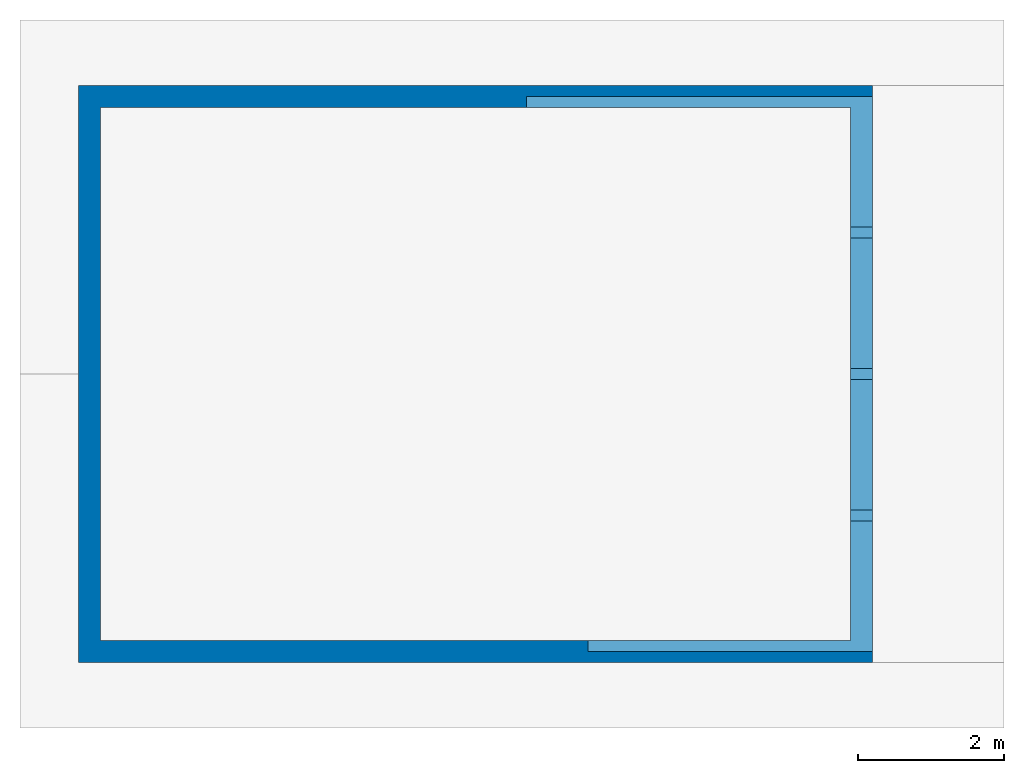
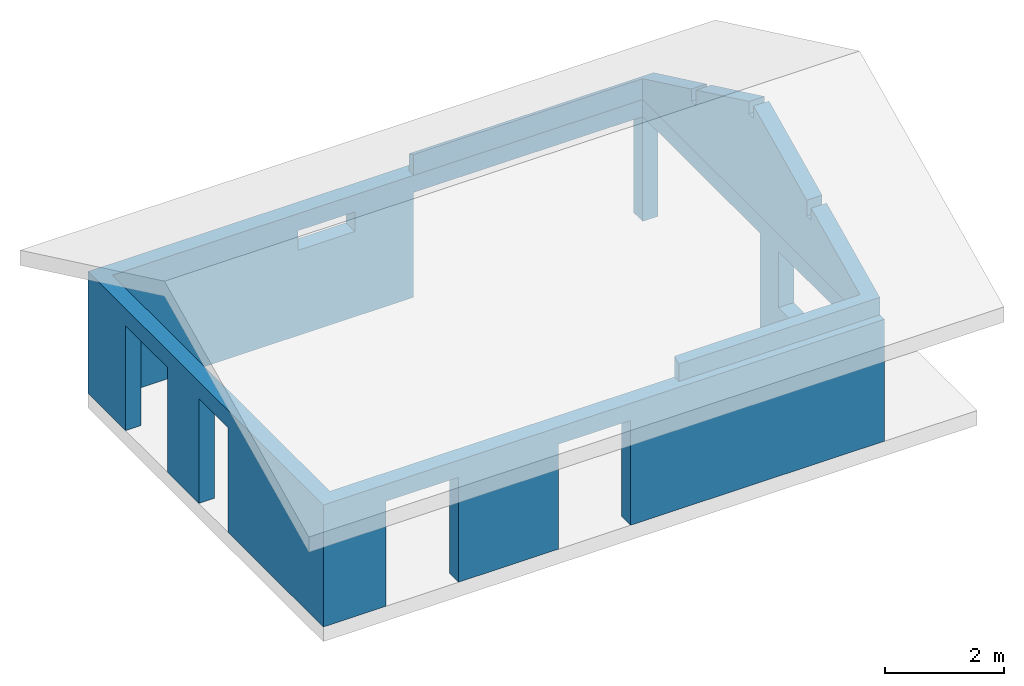
# Not in any storey, part 2 of 2: 2 walls.
"""IFC4 model written with IfcOpenShell, lengths in metres."""

from ifc_helpers import new_model, entity, si_unit, converted_unit, frame, frame_2d, origin_with_axes, place, context, subcontext, project, polygons, material, element, save


model = new_model("IFC4")

# Units and contexts
model_context = context("Model", 3, precision=1e-05, world=origin_with_axes())
plan_context = context("Plan", 2, precision=1e-05, world=frame_2d((0.0, 0.0, 0.0), x_axis=(1.0, 0.0, 0.0)))
body_context = subcontext(model_context, "Body", "Model", "MODEL_VIEW")
ifc_project = project(units=[converted_unit("PLANEANGLEUNIT", "degree", entity("IfcReal", 0.0174532925199433), si_unit("PLANEANGLEUNIT", "RADIAN"), dimensions=[0, 0, 0, 0, 0, 0, 0]), si_unit("AREAUNIT", "SQUARE_METRE"), si_unit("VOLUMEUNIT", "CUBIC_METRE"), si_unit("LENGTHUNIT", "METRE")], contexts=[model_context, plan_context])

# Walls
ifc_material = material(Name="brick")
wall_1_placement = place(None, frame((0.0, 0.0, 0.300000011920929), z_axis=(0.0, 0.0, 1.0), x_axis=(1.0, 0.0, 0.0)))
element("IfcWall", 1, at=wall_1_placement, material=ifc_material, PredefinedType="ELEMENTEDWALL", context=body_context, shape_type="Tessellation", body=[
    polygons([(-0.0500000007450581, 3.77999997138977, 2.15000009536743), (-0.349999994039536, 3.77999997138977, 0.0), (-0.0500000007450581, 3.77999997138977, 0.0), (-0.349999994039536, 3.77999997138977, 2.15000009536743), (-0.349999994039536, 2.79999995231628, 2.15000009536743), (-0.0500000007450581, 2.79999995231628, 2.15000009536743), (-0.0500000007450581, 2.79999995231628, 0.0), (-0.349999994039536, 2.79999995231628, 0.0), (10.5299997329712, 7.5, 0.0), (10.5299997329712, 7.19999980926514, 2.15000009536743), (10.5299997329712, 7.19999980926514, 0.0), (10.5299997329712, 7.5, 2.15000009536743), (3.34999990463257, 7.19999980926514, 2.5), (3.25, 7.19999980926514, 0.0), (3.34999990463257, 7.19999980926514, 0.0), (3.25, 7.19999980926514, 2.5), (5.69000005722046, 7.19999980926514, 2.5), (5.69000005722046, 7.19999980926514, 0.0), (4.65000009536743, 7.19999980926514, 1.75), (4.65000009536743, 7.19999980926514, 2.15000009536743), (3.54999995231628, 7.19999980926514, 2.15000009536743), (4.65000009536743, 7.19999980926514, 2.5), (3.54999995231628, 7.19999980926514, 1.75), (3.54999995231628, 7.19999980926514, 2.5), (3.19000005722046, -0.100000001490116, 2.5), (3.28999996185303, -0.100000001490116, 0.0), (3.19000005722046, -0.100000001490116, 0.0), (3.28999996185303, -0.100000001490116, 2.5), (-0.0500000007450581, 7.19999980926514, 0.0), (-0.0500000007450581, 7.19999980926514, 2.5), (6.53000020980835, -0.100000001490116, 2.5), (6.63000011444092, -0.100000001490116, 0.0), (6.53000020980835, -0.100000001490116, 0.0), (6.63000011444092, -0.100000001490116, 2.5), (2.26999998092651, -0.100000001490116, 2.15000009536743), (0.870000004768372, -0.400000005960464, 2.15000009536743), (0.870000004768372, -0.100000001490116, 2.15000009536743), (2.26999998092651, -0.400000005960464, 2.15000009536743), (0.870000004768372, -0.100000001490116, 0.0), (0.870000004768372, -0.400000005960464, 0.0), (2.26999998092651, -0.400000005960464, 0.0), (2.26999998092651, -0.100000001490116, 0.0), (5.6100001335144, -0.100000001490116, 2.15000009536743), (5.6100001335144, -0.400000005960464, 0.0), (5.6100001335144, -0.400000005960464, 2.15000009536743), (5.6100001335144, -0.100000001490116, 0.0), (4.21000003814697, -0.400000005960464, 2.15000009536743), (4.21000003814697, -0.100000001490116, 2.15000009536743), (-0.349999994039536, 4.84000015258789, 2.15000009536743), (-0.0500000007450581, 4.84000015258789, 0.0), (-0.349999994039536, 4.84000015258789, 0.0), (-0.0500000007450581, 4.84000015258789, 2.15000009536743), (4.21000003814697, -0.100000001490116, 0.0), (4.21000003814697, -0.400000005960464, 0.0), (10.2299995422363, -0.100000001490116, 0.0), (10.2299995422363, -0.100000001490116, 2.5), (-0.0500000007450581, 6.23999977111816, 2.15000009536743), (-0.349999994039536, 6.23999977111816, 0.0), (-0.0500000007450581, 6.23999977111816, 0.0), (-0.349999994039536, 6.23999977111816, 2.15000009536743), (10.2299995422363, 0.639999985694885, 2.5), (10.2299995422363, 0.639999985694885, 1.0), (10.2299995422363, 0.639999985694885, 2.15000009536743), (10.2299995422363, 2.64000010490417, 2.5), (10.2299995422363, 2.64000010490417, 2.15000009536743), (10.2299995422363, 3.25999999046326, 2.5), (10.2299995422363, 2.64000010490417, 1.0), (10.2299995422363, 4.09000015258789, 2.5), (10.2299995422363, 3.25999999046326, 2.15000009536743), (10.2299995422363, 7.19999980926514, 2.15000009536743), (10.2299995422363, 4.19000005722046, 2.5), (10.2299995422363, 5.64499998092651, 2.5), (10.2299995422363, 5.74499988555908, 2.5), (10.2299995422363, 7.19999980926514, 2.5), (10.2299995422363, 3.25999999046326, 0.0), (10.5299997329712, 3.25999999046326, 0.0), (10.5299997329712, 3.25999999046326, 2.15000009536743), (10.2299995422363, 7.19999980926514, 0.0), (10.2299995422363, 7.5, 0.0), (-0.0500000007450581, -0.100000001490116, 2.5), (-0.0500000007450581, -0.100000001490116, 0.0), (-0.0500000007450581, 2.79999995231628, 2.5), (-0.0500000007450581, 3.88000011444092, 0.0), (-0.0500000007450581, 3.77999997138977, 2.5), (-0.0500000007450581, 3.88000011444092, 2.5), (4.21000003814697, -0.100000001490116, 2.5), (5.6100001335144, -0.100000001490116, 2.5), (10.5299997329712, -0.400000005960464, 0.0), (-0.349999994039536, -0.400000005960464, 0.0), (0.870000004768372, -0.100000001490116, 2.5), (2.26999998092651, -0.100000001490116, 2.5), (10.5299997329712, -0.400000005960464, 2.5), (-0.349999994039536, -0.400000005960464, 2.5), (5.6100001335144, -0.400000005960464, 2.5), (4.21000003814697, -0.400000005960464, 2.5), (2.26999998092651, -0.400000005960464, 2.5), (0.870000004768372, -0.400000005960464, 2.5), (-0.0500000007450581, 6.23999977111816, 2.5), (-0.0500000007450581, 4.84000015258789, 2.5), (-0.349999994039536, 7.5, 0.0), (5.78999996185303, 7.5, 0.0), (5.78999996185303, 7.19999980926514, 0.0), (10.5299997329712, 0.639999985694885, 1.0), (10.5299997329712, 2.64000010490417, 1.0), (10.5299997329712, 0.639999985694885, 2.15000009536743), (10.5299997329712, 2.64000010490417, 2.15000009536743), (10.5299997329712, 3.25999999046326, 2.5), (10.5299997329712, 2.64000010490417, 2.5), (-0.349999994039536, 3.77999997138977, 2.5), (-0.349999994039536, 2.79999995231628, 2.5), (-0.349999994039536, 4.84000015258789, 2.5), (-0.349999994039536, 6.23999977111816, 2.5), (-0.349999994039536, 7.5, 2.5), (10.5299997329712, 0.639999985694885, 2.5), (5.78999996185303, 7.19999980926514, 2.15000009536743), (5.78999996185303, 7.5, 2.15000009536743), (10.2299995422363, 7.5, 2.15000009536743), (4.65000009536743, 7.5, 1.75), (3.54999995231628, 7.5, 1.75), (4.65000009536743, 7.5, 2.15000009536743), (10.5299997329712, 7.5, 2.5), (10.2299995422363, 7.5, 2.5), (7.20333337783813, 7.5, 2.5), (7.3033332824707, 7.5, 2.5), (8.71666622161865, 7.5, 2.5), (8.81666660308838, 7.5, 2.5), (3.54999995231628, 7.5, 2.15000009536743), (3.54999995231628, 7.5, 2.5), (5.78999996185303, 7.5, 2.5), (4.65000009536743, 7.5, 2.5), (8.81666660308838, 7.19999980926514, 2.5), (8.71666622161865, 7.19999980926514, 2.5), (7.3033332824707, 7.19999980926514, 2.5), (7.20333337783813, 7.19999980926514, 2.5), (5.78999996185303, 7.19999980926514, 2.5), (10.5299997329712, 5.74499988555908, 2.5), (10.5299997329712, 7.19999980926514, 2.5), (10.5299997329712, 4.09000015258789, 2.5), (10.5299997329712, 4.19000005722046, 2.5), (10.5299997329712, 5.64499998092651, 2.5)], [[[1, 2, 3]], [[2, 1, 4]], [[1, 5, 4]], [[5, 1, 6]], [[5, 7, 8]], [[7, 5, 6]], [[9, 10, 11]], [[10, 9, 12]], [[13, 14, 15]], [[14, 13, 16]], [[17, 15, 18]], [[15, 17, 19]], [[19, 17, 20]], [[20, 17, 21]], [[21, 17, 22]], [[15, 23, 13]], [[23, 15, 19]], [[13, 23, 21]], [[13, 21, 24]], [[24, 21, 22]], [[25, 26, 27]], [[26, 25, 28]], [[16, 29, 14]], [[29, 16, 30]], [[31, 32, 33]], [[32, 31, 34]], [[35, 36, 37]], [[36, 35, 38]], [[39, 36, 40]], [[36, 39, 37]], [[35, 41, 38]], [[41, 35, 42]], [[43, 44, 45]], [[44, 43, 46]], [[43, 47, 48]], [[47, 43, 45]], [[49, 50, 51]], [[50, 49, 52]], [[53, 47, 54]], [[47, 53, 48]], [[34, 55, 32]], [[55, 34, 56]], [[57, 58, 59]], [[58, 57, 60]], [[57, 49, 60]], [[49, 57, 52]], [[61, 55, 56]], [[55, 61, 62]], [[62, 61, 63]], [[63, 61, 64]], [[63, 64, 65]], [[65, 64, 66]], [[65, 66, 67]], [[68, 69, 66]], [[69, 68, 70]], [[70, 68, 71]], [[70, 71, 72]], [[70, 72, 73]], [[70, 73, 74]], [[62, 75, 55]], [[75, 62, 67]], [[75, 67, 66]], [[75, 66, 69]], [[69, 76, 75]], [[76, 69, 77]], [[9, 78, 79]], [[78, 9, 11]], [[7, 80, 81]], [[80, 7, 82]], [[82, 7, 6]], [[83, 1, 3]], [[1, 83, 84]], [[84, 83, 85]], [[1, 82, 6]], [[82, 1, 84]], [[28, 53, 26]], [[53, 28, 48]], [[48, 28, 43]], [[43, 33, 46]], [[33, 43, 31]], [[31, 43, 28]], [[31, 28, 86]], [[31, 86, 87]], [[76, 55, 75]], [[33, 44, 46]], [[44, 33, 88]], [[88, 33, 32]], [[88, 32, 55]], [[88, 55, 76]], [[7, 89, 8]], [[89, 7, 81]], [[89, 81, 40]], [[40, 81, 39]], [[27, 41, 42]], [[41, 27, 54]], [[54, 27, 26]], [[54, 26, 53]], [[80, 39, 81]], [[39, 80, 37]], [[37, 80, 35]], [[35, 27, 42]], [[27, 35, 25]], [[25, 35, 80]], [[25, 80, 90]], [[25, 90, 91]], [[92, 44, 88]], [[44, 92, 45]], [[45, 92, 47]], [[47, 92, 38]], [[38, 92, 36]], [[36, 89, 40]], [[89, 36, 93]], [[93, 36, 92]], [[93, 92, 94]], [[93, 94, 95]], [[93, 95, 96]], [[93, 96, 97]], [[50, 2, 51]], [[2, 50, 3]], [[3, 50, 83]], [[29, 57, 59]], [[57, 29, 98]], [[98, 29, 30]], [[50, 85, 83]], [[85, 50, 99]], [[99, 50, 52]], [[99, 52, 57]], [[99, 57, 98]], [[49, 2, 4]], [[2, 49, 51]], [[100, 29, 58]], [[29, 100, 101]], [[29, 101, 14]], [[14, 101, 15]], [[15, 101, 18]], [[18, 101, 102]], [[59, 58, 29]], [[103, 67, 62]], [[67, 103, 104]], [[63, 103, 62]], [[103, 63, 105]], [[106, 63, 65]], [[63, 106, 105]], [[106, 67, 104]], [[67, 106, 65]], [[47, 41, 54]], [[41, 47, 38]], [[94, 86, 95]], [[86, 94, 87]], [[64, 107, 66]], [[107, 64, 108]], [[96, 90, 97]], [[90, 96, 91]], [[95, 91, 96]], [[91, 95, 25]], [[25, 95, 28]], [[28, 95, 86]], [[109, 5, 110]], [[5, 109, 4]], [[4, 109, 111]], [[4, 111, 49]], [[49, 111, 112]], [[49, 112, 60]], [[60, 112, 113]], [[60, 113, 58]], [[58, 113, 100]], [[110, 89, 93]], [[89, 110, 8]], [[8, 110, 5]], [[84, 111, 109]], [[111, 84, 99]], [[99, 84, 85]], [[99, 112, 111]], [[112, 99, 98]], [[82, 110, 80]], [[93, 80, 110]], [[80, 93, 97]], [[80, 97, 90]], [[82, 109, 110]], [[109, 82, 84]], [[114, 64, 61]], [[64, 114, 108]], [[92, 87, 94]], [[87, 92, 31]], [[31, 92, 34]], [[34, 92, 56]], [[56, 92, 61]], [[61, 92, 114]], [[101, 115, 102]], [[115, 101, 116]], [[10, 78, 11]], [[78, 10, 70]], [[10, 69, 70]], [[69, 10, 77]], [[117, 78, 70]], [[78, 117, 79]], [[117, 9, 79]], [[9, 117, 12]], [[12, 70, 117]], [[70, 12, 10]], [[116, 70, 115]], [[70, 116, 117]], [[101, 118, 116]], [[118, 101, 119]], [[116, 118, 120]], [[117, 121, 12]], [[121, 117, 116]], [[121, 116, 120]], [[121, 120, 122]], [[122, 120, 123]], [[122, 123, 124]], [[122, 124, 125]], [[122, 125, 126]], [[113, 101, 100]], [[101, 113, 119]], [[119, 113, 127]], [[127, 113, 120]], [[120, 113, 123]], [[123, 113, 128]], [[123, 128, 129]], [[130, 129, 128]], [[98, 113, 112]], [[113, 98, 30]], [[113, 30, 128]], [[128, 30, 16]], [[128, 16, 13]], [[128, 13, 24]], [[131, 125, 132]], [[125, 131, 126]], [[132, 124, 133]], [[124, 132, 125]], [[133, 123, 134]], [[123, 133, 124]], [[134, 129, 135]], [[129, 134, 123]], [[136, 74, 73]], [[74, 136, 137]], [[74, 115, 70]], [[115, 18, 102]], [[18, 115, 17]], [[17, 115, 135]], [[135, 115, 134]], [[134, 115, 74]], [[134, 74, 131]], [[134, 131, 132]], [[134, 132, 133]], [[137, 122, 74]], [[122, 137, 121]], [[88, 103, 92]], [[103, 88, 76]], [[103, 76, 104]], [[104, 76, 106]], [[106, 76, 108]], [[108, 76, 107]], [[107, 76, 77]], [[107, 77, 10]], [[107, 10, 138]], [[138, 10, 139]], [[139, 10, 140]], [[140, 10, 136]], [[136, 10, 137]], [[137, 10, 121]], [[121, 10, 12]], [[103, 114, 92]], [[114, 103, 105]], [[114, 105, 106]], [[114, 106, 108]], [[74, 126, 131]], [[126, 74, 122]], [[140, 73, 72]], [[73, 140, 136]], [[139, 72, 71]], [[72, 139, 140]], [[138, 71, 68]], [[71, 138, 139]], [[66, 138, 68]], [[138, 66, 107]], [[119, 21, 23]], [[21, 119, 127]], [[19, 119, 23]], [[119, 19, 118]], [[120, 19, 20]], [[19, 120, 118]], [[120, 21, 127]], [[21, 120, 20]], [[22, 128, 24]], [[128, 22, 130]], [[17, 130, 22]], [[130, 17, 129]], [[129, 17, 135]]]),
])
wall_2_placement = place(None, frame((10.5299997329712, -0.25, 2.79999995231628), z_axis=(0.0, 8.74227765734759e-08, -1.0), x_axis=(1.0, 0.0, 0.0)))
element("IfcWall", 2, at=wall_2_placement, PredefinedType="ELEMENTEDWALL", context=body_context, shape_type="Tessellation", body=[
    polygons([(0.0, -1.78705203533173, -1.20818710327148), (0.0, -1.78705203533173, -0.959593713283539), (0.0, -1.80477852701956e-16, -0.35854572057724), (0.0, -3.7241039276123, -2.12914514541626), (0.0, -1.93705201148987, -0.959593713283539), (0.0, -1.93705201148987, -1.27950358390808), (0.0, -3.7241039276123, -1.87800002098083), (0.0, -5.66294813156128, -1.27950358390808), (0.0, -3.87410402297974, -1.87800002098083), (0.0, -3.87410402297974, -2.12999701499939), (0.0, -7.59999990463257, -0.35854572057724), (0.0, -5.81294822692871, -0.959593713283539), (0.0, -5.81294822692871, -1.20818710327148), (0.0, -7.59999990463257, 0.0), (0.0, 0.0, -3.60955705403911e-16), (0.0, -5.66294813156128, -0.959593713283539), (-4.73999977111816, -7.59999990463257, -7.21911442571558e-15), (-4.73999977111816, -7.59999990463257, -0.35854572057724), (-0.300000011920929, -5.81294822692871, -1.20818710327148), (-0.300000011920929, -7.44999980926514, -0.429862201213837), (-4.73999977111816, -7.44999980926514, -0.429862201213837), (-0.300000011920929, -5.81294822692871, -0.959593713283539), (-0.300000011920929, -5.66294813156128, -0.959593713283539), (-0.300000011920929, -5.66294813156128, -1.27950358390808), (-0.300000011920929, -3.87410402297974, -2.12999701499939), (-0.300000011920929, -3.87410402297974, -1.87800002098083), (-0.300000011920929, -3.7241039276123, -1.87800002098083), (-0.300000011920929, -3.7241039276123, -2.12914514541626), (-0.300000011920929, -1.93705201148987, -1.27950358390808), (-0.300000011920929, -1.93705201148987, -0.959593713283539), (-0.300000011920929, -1.78705203533173, -0.959593713283539), (-0.300000011920929, -1.78705203533173, -1.20818710327148), (-0.300000011920929, -0.150000005960464, -0.429862201213837), (-3.90000009536743, -1.80477852701956e-16, -0.35854572057724), (-3.90000009536743, -0.150000005960464, -0.429862201213837), (-3.90000009536743, 0.0, -3.60955705403911e-16), (-0.300000011920929, -7.44999980926514, 3.97051268003368e-15), (-0.300000011920929, -0.150000005960464, -3.60955705403911e-16), (-4.73999977111816, -7.44999980926514, -3.24860132216542e-15), (-3.90000009536743, -0.150000005960464, -3.60955705403911e-16)], [[[1, 2, 3]], [[4, 5, 6]], [[5, 4, 7]], [[8, 9, 10]], [[11, 12, 13]], [[3, 14, 15]], [[14, 3, 2]], [[14, 2, 5]], [[14, 5, 7]], [[14, 7, 16]], [[16, 7, 9]], [[16, 9, 8]], [[14, 16, 12]], [[14, 12, 11]]]),
    polygons([(0.0, -1.78705203533173, -1.20818710327148), (0.0, -1.78705203533173, -0.959593713283539), (0.0, -1.80477852701956e-16, -0.35854572057724), (0.0, -3.7241039276123, -2.12914514541626), (0.0, -1.93705201148987, -0.959593713283539), (0.0, -1.93705201148987, -1.27950358390808), (0.0, -3.7241039276123, -1.87800002098083), (0.0, -5.66294813156128, -1.27950358390808), (0.0, -3.87410402297974, -1.87800002098083), (0.0, -3.87410402297974, -2.12999701499939), (0.0, -7.59999990463257, -0.35854572057724), (0.0, -5.81294822692871, -0.959593713283539), (0.0, -5.81294822692871, -1.20818710327148), (0.0, -7.59999990463257, 0.0), (0.0, 0.0, -3.60955705403911e-16), (0.0, -5.66294813156128, -0.959593713283539), (-4.73999977111816, -7.59999990463257, -7.21911442571558e-15), (-4.73999977111816, -7.59999990463257, -0.35854572057724), (-0.300000011920929, -5.81294822692871, -1.20818710327148), (-0.300000011920929, -7.44999980926514, -0.429862201213837), (-4.73999977111816, -7.44999980926514, -0.429862201213837), (-0.300000011920929, -5.81294822692871, -0.959593713283539), (-0.300000011920929, -5.66294813156128, -0.959593713283539), (-0.300000011920929, -5.66294813156128, -1.27950358390808), (-0.300000011920929, -3.87410402297974, -2.12999701499939), (-0.300000011920929, -3.87410402297974, -1.87800002098083), (-0.300000011920929, -3.7241039276123, -1.87800002098083), (-0.300000011920929, -3.7241039276123, -2.12914514541626), (-0.300000011920929, -1.93705201148987, -1.27950358390808), (-0.300000011920929, -1.93705201148987, -0.959593713283539), (-0.300000011920929, -1.78705203533173, -0.959593713283539), (-0.300000011920929, -1.78705203533173, -1.20818710327148), (-0.300000011920929, -0.150000005960464, -0.429862201213837), (-3.90000009536743, -1.80477852701956e-16, -0.35854572057724), (-3.90000009536743, -0.150000005960464, -0.429862201213837), (-3.90000009536743, 0.0, -3.60955705403911e-16), (-0.300000011920929, -7.44999980926514, 3.97051268003368e-15), (-0.300000011920929, -0.150000005960464, -3.60955705403911e-16), (-4.73999977111816, -7.44999980926514, -3.24860132216542e-15), (-3.90000009536743, -0.150000005960464, -3.60955705403911e-16)], [[[11, 17, 14]], [[17, 11, 18]], [[19, 11, 13]], [[11, 19, 20]], [[11, 20, 18]], [[18, 20, 21]], [[19, 12, 22]], [[12, 19, 13]], [[23, 12, 16]], [[12, 23, 22]], [[8, 23, 16]], [[23, 8, 24]], [[25, 8, 10]], [[8, 25, 24]], [[25, 9, 26]], [[9, 25, 10]], [[27, 9, 7]], [[9, 27, 26]], [[4, 27, 7]], [[27, 4, 28]], [[29, 4, 6]], [[4, 29, 28]], [[29, 5, 30]], [[5, 29, 6]], [[31, 5, 2]], [[5, 31, 30]], [[1, 31, 2]], [[31, 1, 32]], [[1, 3, 33]], [[33, 3, 34]], [[33, 34, 35]], [[32, 1, 33]], [[34, 15, 36]], [[15, 34, 3]], [[14, 37, 15]], [[37, 14, 17]], [[15, 37, 38]], [[37, 17, 39]], [[38, 36, 15]], [[36, 38, 40]]]),
    polygons([(0.0, -1.78705203533173, -1.20818710327148), (0.0, -1.78705203533173, -0.959593713283539), (0.0, -1.80477852701956e-16, -0.35854572057724), (0.0, -3.7241039276123, -2.12914514541626), (0.0, -1.93705201148987, -0.959593713283539), (0.0, -1.93705201148987, -1.27950358390808), (0.0, -3.7241039276123, -1.87800002098083), (0.0, -5.66294813156128, -1.27950358390808), (0.0, -3.87410402297974, -1.87800002098083), (0.0, -3.87410402297974, -2.12999701499939), (0.0, -7.59999990463257, -0.35854572057724), (0.0, -5.81294822692871, -0.959593713283539), (0.0, -5.81294822692871, -1.20818710327148), (0.0, -7.59999990463257, 0.0), (0.0, 0.0, -3.60955705403911e-16), (0.0, -5.66294813156128, -0.959593713283539), (-4.73999977111816, -7.59999990463257, -7.21911442571558e-15), (-4.73999977111816, -7.59999990463257, -0.35854572057724), (-0.300000011920929, -5.81294822692871, -1.20818710327148), (-0.300000011920929, -7.44999980926514, -0.429862201213837), (-4.73999977111816, -7.44999980926514, -0.429862201213837), (-0.300000011920929, -5.81294822692871, -0.959593713283539), (-0.300000011920929, -5.66294813156128, -0.959593713283539), (-0.300000011920929, -5.66294813156128, -1.27950358390808), (-0.300000011920929, -3.87410402297974, -2.12999701499939), (-0.300000011920929, -3.87410402297974, -1.87800002098083), (-0.300000011920929, -3.7241039276123, -1.87800002098083), (-0.300000011920929, -3.7241039276123, -2.12914514541626), (-0.300000011920929, -1.93705201148987, -1.27950358390808), (-0.300000011920929, -1.93705201148987, -0.959593713283539), (-0.300000011920929, -1.78705203533173, -0.959593713283539), (-0.300000011920929, -1.78705203533173, -1.20818710327148), (-0.300000011920929, -0.150000005960464, -0.429862201213837), (-3.90000009536743, -1.80477852701956e-16, -0.35854572057724), (-3.90000009536743, -0.150000005960464, -0.429862201213837), (-3.90000009536743, 0.0, -3.60955705403911e-16), (-0.300000011920929, -7.44999980926514, 3.97051268003368e-15), (-0.300000011920929, -0.150000005960464, -3.60955705403911e-16), (-4.73999977111816, -7.44999980926514, -3.24860132216542e-15), (-3.90000009536743, -0.150000005960464, -3.60955705403911e-16)], [[[40, 34, 36]], [[34, 40, 35]], [[33, 40, 38]], [[40, 33, 35]], [[37, 33, 38]], [[33, 37, 31]], [[31, 37, 30]], [[30, 37, 29]], [[29, 37, 27]], [[27, 37, 26]], [[26, 37, 23]], [[23, 37, 22]], [[22, 37, 19]], [[19, 37, 20]], [[26, 24, 25]], [[24, 26, 23]], [[28, 29, 27]], [[32, 33, 31]], [[17, 21, 39]], [[21, 17, 18]], [[39, 20, 37]], [[20, 39, 21]]]),
])

save(model, "model.ifc")
